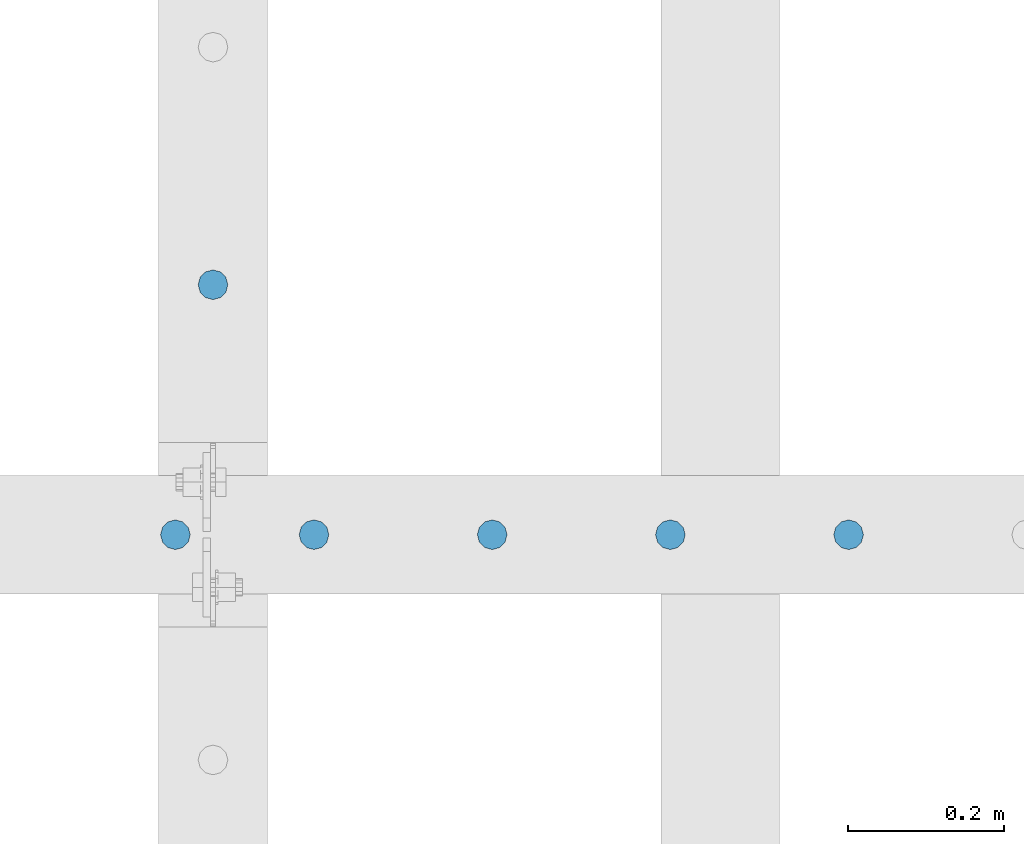
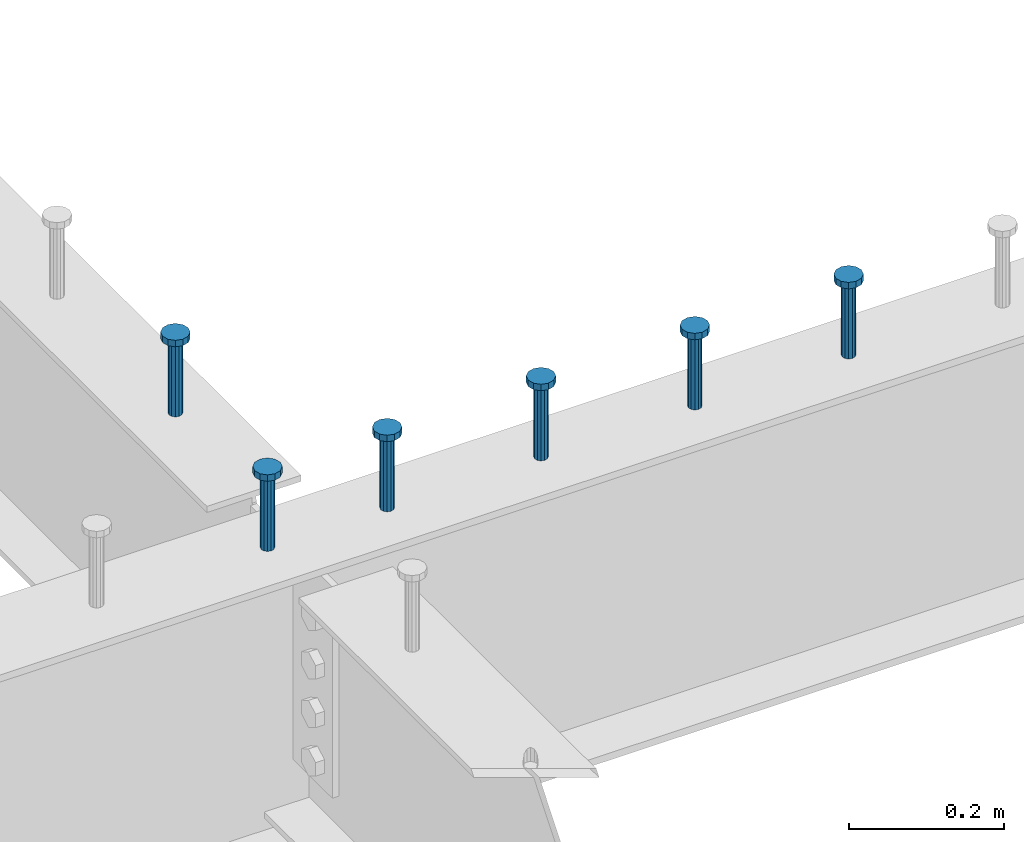
# One storey, part 167 of 975: 6 columns.
"""IFC2X3 building model written with IfcOpenShell, lengths in millimetres."""

from ifc_helpers import new_model, si_unit, frame, origin_with_axes, place, context, subcontext, project, spatial, faceted_brep, material, type_object, element, save


model = new_model("IFC2X3")

# Units and contexts
model_context = context("Model", 3, precision=1e-05, world=origin_with_axes())
body_context = subcontext(model_context, "Body", "Model", "MODEL_VIEW")
ifc_project = project(units=[si_unit("LENGTHUNIT", "METRE", prefix="MILLI"), si_unit("AREAUNIT", "SQUARE_METRE"), si_unit("VOLUMEUNIT", "CUBIC_METRE"), si_unit("MASSUNIT", "GRAM", prefix="KILO"), si_unit("TIMEUNIT", "SECOND"), si_unit("PLANEANGLEUNIT", "RADIAN"), si_unit("SOLIDANGLEUNIT", "STERADIAN"), si_unit("THERMODYNAMICTEMPERATUREUNIT", "DEGREE_CELSIUS"), si_unit("LUMINOUSINTENSITYUNIT", "LUMEN")], contexts=[model_context])

# Site, building, storey
site_placement = place(None, origin_with_axes())
site = spatial("IfcSite", under=ifc_project, at=site_placement, CompositionType="ELEMENT")
building_placement = place(site_placement, origin_with_axes())
building = spatial("IfcBuilding", under=site, at=building_placement, Name="Undefined", CompositionType="ELEMENT")
storey_placement = place(building_placement, origin_with_axes())
storey = spatial("IfcBuildingStorey", under=building, at=storey_placement, Name="Undefined", CompositionType="ELEMENT", Elevation=0.0)

# Columns
ifc_material = material(Name="STEEL/A108")
column_type = type_object("IfcColumnType", Name="STUD_3/4-DIA", PredefinedType="NOTDEFINED")
column_1_placement = place(storey_placement, frame((10858.5662704101, 13712.825, 3937.0), z_axis=(0.0, 1.0, 0.0), x_axis=(0.0, 0.0, 1.0)))
element("IfcColumn", 1, at=column_1_placement, inside=storey, type_object=column_type, material=ifc_material, ObjectType="STUD_3/4-DIA", context=body_context, shape_type="Brep", body=[
    faceted_brep([(0.0, -9.52000045776367, 0.0), (0.0, -8.25, -4.76000022888184), (115.57, -8.25, -4.76000022888184), (115.57, -9.52000045776367, 0.0), (0.0, -4.76000022888184, -8.25), (115.57, -4.76000022888184, -8.25), (0.0, 0.0, -9.52000045776367), (115.57, 0.0, -9.52000045776367), (0.0, 4.76000022888184, -8.25), (115.57, 4.76000022888184, -8.25), (0.0, 8.25, -4.76000022888184), (115.57, 8.25, -4.76000022888184), (0.0, 9.52000045776367, 0.0), (115.57, 9.52000045776367, 0.0), (0.0, 8.25, 4.76000022888184), (115.57, 8.25, 4.76000022888184), (0.0, 4.76000022888184, 8.25), (115.57, 4.76000022888184, 8.25), (0.0, 0.0, 9.52000045776367), (115.57, 0.0, 9.52000045776367), (0.0, -4.76000022888184, 8.25), (115.57, -4.76000022888184, 8.25), (0.0, -8.25, 4.76000022888184), (115.57, -8.25, 4.76000022888184), (116.84, -16.5, -9.52000045776367), (116.84, -19.0499992370605, 0.0), (116.84, -9.52000045776367, -16.5), (116.84, 0.0, -19.0499992370605), (116.84, 9.52000045776367, -16.5), (116.84, 16.5, -9.52000045776367), (116.84, 19.0499992370605, 0.0), (116.84, 16.5, 9.52000045776367), (116.84, 9.52000045776367, 16.5), (116.84, 0.0, 19.0499992370605), (116.84, -9.52000045776367, 16.5), (116.84, -16.5, 9.52000045776367), (127.0, -16.5, -9.52000045776367), (127.0, -19.0499992370605, 0.0), (127.0, -9.52000045776367, -16.5), (127.0, 0.0, -19.0499992370605), (127.0, 9.52000045776367, -16.5), (127.0, 16.5, -9.52000045776367), (127.0, 19.0499992370605, 0.0), (127.0, 16.5, 9.52000045776367), (127.0, 9.52000045776367, 16.5), (127.0, 0.0, 19.0499992370605), (127.0, -9.52000045776367, 16.5), (127.0, -16.5, 9.52000045776367)], [[[0, 1, 2, 3]], [[1, 4, 5, 2]], [[4, 6, 7, 5]], [[6, 8, 9, 7]], [[8, 10, 11, 9]], [[10, 12, 13, 11]], [[12, 14, 15, 13]], [[14, 16, 17, 15]], [[16, 18, 19, 17]], [[18, 20, 21, 19]], [[20, 22, 23, 21]], [[22, 0, 3, 23]], [[22, 20, 18, 16, 14, 12, 10, 8, 6, 4, 1, 0]], [[3, 2, 24, 25]], [[2, 5, 26, 24]], [[5, 7, 27, 26]], [[7, 9, 28, 27]], [[9, 11, 29, 28]], [[11, 13, 30, 29]], [[13, 15, 31, 30]], [[15, 17, 32, 31]], [[17, 19, 33, 32]], [[19, 21, 34, 33]], [[21, 23, 35, 34]], [[23, 3, 25, 35]], [[25, 24, 36, 37]], [[24, 26, 38, 36]], [[26, 27, 39, 38]], [[27, 28, 40, 39]], [[28, 29, 41, 40]], [[29, 30, 42, 41]], [[30, 31, 43, 42]], [[31, 32, 44, 43]], [[32, 33, 45, 44]], [[33, 34, 46, 45]], [[34, 35, 47, 46]], [[35, 25, 37, 47]], [[38, 39, 40, 41, 42, 43, 44, 45, 46, 47, 37, 36]]]),
])
column_2_placement = place(storey_placement, frame((11673.9459584101, 13392.15, 3937.0), z_axis=(0.0, 1.0, 0.0), x_axis=(0.0, 0.0, 1.0)))
element("IfcColumn", 2, at=column_2_placement, inside=storey, type_object=column_type, material=ifc_material, ObjectType="STUD_3/4-DIA", context=body_context, shape_type="Brep", body=[
    faceted_brep([(0.0, -9.52000045776367, 0.0), (0.0, -8.25, -4.76000022888184), (115.57, -8.25, -4.76000022888184), (115.57, -9.52000045776367, 0.0), (0.0, -4.76000022888184, -8.25), (115.57, -4.76000022888184, -8.25), (0.0, 0.0, -9.52000045776367), (115.57, 0.0, -9.52000045776367), (0.0, 4.76000022888184, -8.25), (115.57, 4.76000022888184, -8.25), (0.0, 8.25, -4.76000022888184), (115.57, 8.25, -4.76000022888184), (0.0, 9.52000045776367, 0.0), (115.57, 9.52000045776367, 0.0), (0.0, 8.25, 4.76000022888184), (115.57, 8.25, 4.76000022888184), (0.0, 4.76000022888184, 8.25), (115.57, 4.76000022888184, 8.25), (0.0, 0.0, 9.52000045776367), (115.57, 0.0, 9.52000045776367), (0.0, -4.76000022888184, 8.25), (115.57, -4.76000022888184, 8.25), (0.0, -8.25, 4.76000022888184), (115.57, -8.25, 4.76000022888184), (116.84, -16.5, -9.52000045776367), (116.84, -19.0499992370605, 0.0), (116.84, -9.52000045776367, -16.5), (116.84, 0.0, -19.0499992370605), (116.84, 9.52000045776367, -16.5), (116.84, 16.5, -9.52000045776367), (116.84, 19.0499992370605, 0.0), (116.84, 16.5, 9.52000045776367), (116.84, 9.52000045776367, 16.5), (116.84, 0.0, 19.0499992370605), (116.84, -9.52000045776367, 16.5), (116.84, -16.5, 9.52000045776367), (127.0, -16.5, -9.52000045776367), (127.0, -19.0499992370605, 0.0), (127.0, -9.52000045776367, -16.5), (127.0, 0.0, -19.0499992370605), (127.0, 9.52000045776367, -16.5), (127.0, 16.5, -9.52000045776367), (127.0, 19.0499992370605, 0.0), (127.0, 16.5, 9.52000045776367), (127.0, 9.52000045776367, 16.5), (127.0, 0.0, 19.0499992370605), (127.0, -9.52000045776367, 16.5), (127.0, -16.5, 9.52000045776367)], [[[0, 1, 2, 3]], [[1, 4, 5, 2]], [[4, 6, 7, 5]], [[6, 8, 9, 7]], [[8, 10, 11, 9]], [[10, 12, 13, 11]], [[12, 14, 15, 13]], [[14, 16, 17, 15]], [[16, 18, 19, 17]], [[18, 20, 21, 19]], [[20, 22, 23, 21]], [[22, 0, 3, 23]], [[22, 20, 18, 16, 14, 12, 10, 8, 6, 4, 1, 0]], [[3, 2, 24, 25]], [[2, 5, 26, 24]], [[5, 7, 27, 26]], [[7, 9, 28, 27]], [[9, 11, 29, 28]], [[11, 13, 30, 29]], [[13, 15, 31, 30]], [[15, 17, 32, 31]], [[17, 19, 33, 32]], [[19, 21, 34, 33]], [[21, 23, 35, 34]], [[23, 3, 25, 35]], [[25, 24, 36, 37]], [[24, 26, 38, 36]], [[26, 27, 39, 38]], [[27, 28, 40, 39]], [[28, 29, 41, 40]], [[29, 30, 42, 41]], [[30, 31, 43, 42]], [[31, 32, 44, 43]], [[32, 33, 45, 44]], [[33, 34, 46, 45]], [[34, 35, 47, 46]], [[35, 25, 37, 47]], [[38, 39, 40, 41, 42, 43, 44, 45, 46, 47, 37, 36]]]),
])
column_3_placement = place(storey_placement, frame((11445.3459584101, 13392.15, 3937.0), z_axis=(0.0, 1.0, 0.0), x_axis=(0.0, 0.0, 1.0)))
element("IfcColumn", 3, at=column_3_placement, inside=storey, type_object=column_type, material=ifc_material, ObjectType="STUD_3/4-DIA", context=body_context, shape_type="Brep", body=[
    faceted_brep([(0.0, -9.52000045776367, 0.0), (0.0, -8.25, -4.76000022888184), (115.57, -8.25, -4.76000022888184), (115.57, -9.52000045776367, 0.0), (0.0, -4.76000022888184, -8.25), (115.57, -4.76000022888184, -8.25), (0.0, 0.0, -9.52000045776367), (115.57, 0.0, -9.52000045776367), (0.0, 4.76000022888184, -8.25), (115.57, 4.76000022888184, -8.25), (0.0, 8.25, -4.76000022888184), (115.57, 8.25, -4.76000022888184), (0.0, 9.52000045776367, 0.0), (115.57, 9.52000045776367, 0.0), (0.0, 8.25, 4.76000022888184), (115.57, 8.25, 4.76000022888184), (0.0, 4.76000022888184, 8.25), (115.57, 4.76000022888184, 8.25), (0.0, 0.0, 9.52000045776367), (115.57, 0.0, 9.52000045776367), (0.0, -4.76000022888184, 8.25), (115.57, -4.76000022888184, 8.25), (0.0, -8.25, 4.76000022888184), (115.57, -8.25, 4.76000022888184), (116.84, -16.5, -9.52000045776367), (116.84, -19.0499992370605, 0.0), (116.84, -9.52000045776367, -16.5), (116.84, 0.0, -19.0499992370605), (116.84, 9.52000045776367, -16.5), (116.84, 16.5, -9.52000045776367), (116.84, 19.0499992370605, 0.0), (116.84, 16.5, 9.52000045776367), (116.84, 9.52000045776367, 16.5), (116.84, 0.0, 19.0499992370605), (116.84, -9.52000045776367, 16.5), (116.84, -16.5, 9.52000045776367), (127.0, -16.5, -9.52000045776367), (127.0, -19.0499992370605, 0.0), (127.0, -9.52000045776367, -16.5), (127.0, 0.0, -19.0499992370605), (127.0, 9.52000045776367, -16.5), (127.0, 16.5, -9.52000045776367), (127.0, 19.0499992370605, 0.0), (127.0, 16.5, 9.52000045776367), (127.0, 9.52000045776367, 16.5), (127.0, 0.0, 19.0499992370605), (127.0, -9.52000045776367, 16.5), (127.0, -16.5, 9.52000045776367)], [[[0, 1, 2, 3]], [[1, 4, 5, 2]], [[4, 6, 7, 5]], [[6, 8, 9, 7]], [[8, 10, 11, 9]], [[10, 12, 13, 11]], [[12, 14, 15, 13]], [[14, 16, 17, 15]], [[16, 18, 19, 17]], [[18, 20, 21, 19]], [[20, 22, 23, 21]], [[22, 0, 3, 23]], [[22, 20, 18, 16, 14, 12, 10, 8, 6, 4, 1, 0]], [[3, 2, 24, 25]], [[2, 5, 26, 24]], [[5, 7, 27, 26]], [[7, 9, 28, 27]], [[9, 11, 29, 28]], [[11, 13, 30, 29]], [[13, 15, 31, 30]], [[15, 17, 32, 31]], [[17, 19, 33, 32]], [[19, 21, 34, 33]], [[21, 23, 35, 34]], [[23, 3, 25, 35]], [[25, 24, 36, 37]], [[24, 26, 38, 36]], [[26, 27, 39, 38]], [[27, 28, 40, 39]], [[28, 29, 41, 40]], [[29, 30, 42, 41]], [[30, 31, 43, 42]], [[31, 32, 44, 43]], [[32, 33, 45, 44]], [[33, 34, 46, 45]], [[34, 35, 47, 46]], [[35, 25, 37, 47]], [[38, 39, 40, 41, 42, 43, 44, 45, 46, 47, 37, 36]]]),
])
column_4_placement = place(storey_placement, frame((11216.7459584101, 13392.15, 3937.0), z_axis=(0.0, 1.0, 0.0), x_axis=(0.0, 0.0, 1.0)))
element("IfcColumn", 4, at=column_4_placement, inside=storey, type_object=column_type, material=ifc_material, ObjectType="STUD_3/4-DIA", context=body_context, shape_type="Brep", body=[
    faceted_brep([(0.0, -9.52000045776367, 0.0), (0.0, -8.25, -4.76000022888184), (115.57, -8.25, -4.76000022888184), (115.57, -9.52000045776367, 0.0), (0.0, -4.76000022888184, -8.25), (115.57, -4.76000022888184, -8.25), (0.0, 0.0, -9.52000045776367), (115.57, 0.0, -9.52000045776367), (0.0, 4.76000022888184, -8.25), (115.57, 4.76000022888184, -8.25), (0.0, 8.25, -4.76000022888184), (115.57, 8.25, -4.76000022888184), (0.0, 9.52000045776367, 0.0), (115.57, 9.52000045776367, 0.0), (0.0, 8.25, 4.76000022888184), (115.57, 8.25, 4.76000022888184), (0.0, 4.76000022888184, 8.25), (115.57, 4.76000022888184, 8.25), (0.0, 0.0, 9.52000045776367), (115.57, 0.0, 9.52000045776367), (0.0, -4.76000022888184, 8.25), (115.57, -4.76000022888184, 8.25), (0.0, -8.25, 4.76000022888184), (115.57, -8.25, 4.76000022888184), (116.84, -16.5, -9.52000045776367), (116.84, -19.0499992370605, 0.0), (116.84, -9.52000045776367, -16.5), (116.84, 0.0, -19.0499992370605), (116.84, 9.52000045776367, -16.5), (116.84, 16.5, -9.52000045776367), (116.84, 19.0499992370605, 0.0), (116.84, 16.5, 9.52000045776367), (116.84, 9.52000045776367, 16.5), (116.84, 0.0, 19.0499992370605), (116.84, -9.52000045776367, 16.5), (116.84, -16.5, 9.52000045776367), (127.0, -16.5, -9.52000045776367), (127.0, -19.0499992370605, 0.0), (127.0, -9.52000045776367, -16.5), (127.0, 0.0, -19.0499992370605), (127.0, 9.52000045776367, -16.5), (127.0, 16.5, -9.52000045776367), (127.0, 19.0499992370605, 0.0), (127.0, 16.5, 9.52000045776367), (127.0, 9.52000045776367, 16.5), (127.0, 0.0, 19.0499992370605), (127.0, -9.52000045776367, 16.5), (127.0, -16.5, 9.52000045776367)], [[[0, 1, 2, 3]], [[1, 4, 5, 2]], [[4, 6, 7, 5]], [[6, 8, 9, 7]], [[8, 10, 11, 9]], [[10, 12, 13, 11]], [[12, 14, 15, 13]], [[14, 16, 17, 15]], [[16, 18, 19, 17]], [[18, 20, 21, 19]], [[20, 22, 23, 21]], [[22, 0, 3, 23]], [[22, 20, 18, 16, 14, 12, 10, 8, 6, 4, 1, 0]], [[3, 2, 24, 25]], [[2, 5, 26, 24]], [[5, 7, 27, 26]], [[7, 9, 28, 27]], [[9, 11, 29, 28]], [[11, 13, 30, 29]], [[13, 15, 31, 30]], [[15, 17, 32, 31]], [[17, 19, 33, 32]], [[19, 21, 34, 33]], [[21, 23, 35, 34]], [[23, 3, 25, 35]], [[25, 24, 36, 37]], [[24, 26, 38, 36]], [[26, 27, 39, 38]], [[27, 28, 40, 39]], [[28, 29, 41, 40]], [[29, 30, 42, 41]], [[30, 31, 43, 42]], [[31, 32, 44, 43]], [[32, 33, 45, 44]], [[33, 34, 46, 45]], [[34, 35, 47, 46]], [[35, 25, 37, 47]], [[38, 39, 40, 41, 42, 43, 44, 45, 46, 47, 37, 36]]]),
])
column_5_placement = place(storey_placement, frame((10988.1459584101, 13392.15, 3937.0), z_axis=(0.0, 1.0, 0.0), x_axis=(0.0, 0.0, 1.0)))
element("IfcColumn", 5, at=column_5_placement, inside=storey, type_object=column_type, material=ifc_material, ObjectType="STUD_3/4-DIA", context=body_context, shape_type="Brep", body=[
    faceted_brep([(0.0, -9.52000045776367, 0.0), (0.0, -8.25, -4.76000022888184), (115.57, -8.25, -4.76000022888184), (115.57, -9.52000045776367, 0.0), (0.0, -4.76000022888184, -8.25), (115.57, -4.76000022888184, -8.25), (0.0, 0.0, -9.52000045776367), (115.57, 0.0, -9.52000045776367), (0.0, 4.76000022888184, -8.25), (115.57, 4.76000022888184, -8.25), (0.0, 8.25, -4.76000022888184), (115.57, 8.25, -4.76000022888184), (0.0, 9.52000045776367, 0.0), (115.57, 9.52000045776367, 0.0), (0.0, 8.25, 4.76000022888184), (115.57, 8.25, 4.76000022888184), (0.0, 4.76000022888184, 8.25), (115.57, 4.76000022888184, 8.25), (0.0, 0.0, 9.52000045776367), (115.57, 0.0, 9.52000045776367), (0.0, -4.76000022888184, 8.25), (115.57, -4.76000022888184, 8.25), (0.0, -8.25, 4.76000022888184), (115.57, -8.25, 4.76000022888184), (116.84, -16.5, -9.52000045776367), (116.84, -19.0499992370605, 0.0), (116.84, -9.52000045776367, -16.5), (116.84, 0.0, -19.0499992370605), (116.84, 9.52000045776367, -16.5), (116.84, 16.5, -9.52000045776367), (116.84, 19.0499992370605, 0.0), (116.84, 16.5, 9.52000045776367), (116.84, 9.52000045776367, 16.5), (116.84, 0.0, 19.0499992370605), (116.84, -9.52000045776367, 16.5), (116.84, -16.5, 9.52000045776367), (127.0, -16.5, -9.52000045776367), (127.0, -19.0499992370605, 0.0), (127.0, -9.52000045776367, -16.5), (127.0, 0.0, -19.0499992370605), (127.0, 9.52000045776367, -16.5), (127.0, 16.5, -9.52000045776367), (127.0, 19.0499992370605, 0.0), (127.0, 16.5, 9.52000045776367), (127.0, 9.52000045776367, 16.5), (127.0, 0.0, 19.0499992370605), (127.0, -9.52000045776367, 16.5), (127.0, -16.5, 9.52000045776367)], [[[0, 1, 2, 3]], [[1, 4, 5, 2]], [[4, 6, 7, 5]], [[6, 8, 9, 7]], [[8, 10, 11, 9]], [[10, 12, 13, 11]], [[12, 14, 15, 13]], [[14, 16, 17, 15]], [[16, 18, 19, 17]], [[18, 20, 21, 19]], [[20, 22, 23, 21]], [[22, 0, 3, 23]], [[22, 20, 18, 16, 14, 12, 10, 8, 6, 4, 1, 0]], [[3, 2, 24, 25]], [[2, 5, 26, 24]], [[5, 7, 27, 26]], [[7, 9, 28, 27]], [[9, 11, 29, 28]], [[11, 13, 30, 29]], [[13, 15, 31, 30]], [[15, 17, 32, 31]], [[17, 19, 33, 32]], [[19, 21, 34, 33]], [[21, 23, 35, 34]], [[23, 3, 25, 35]], [[25, 24, 36, 37]], [[24, 26, 38, 36]], [[26, 27, 39, 38]], [[27, 28, 40, 39]], [[28, 29, 41, 40]], [[29, 30, 42, 41]], [[30, 31, 43, 42]], [[31, 32, 44, 43]], [[32, 33, 45, 44]], [[33, 34, 46, 45]], [[34, 35, 47, 46]], [[35, 25, 37, 47]], [[38, 39, 40, 41, 42, 43, 44, 45, 46, 47, 37, 36]]]),
])
column_6_placement = place(storey_placement, frame((10810.3459584101, 13392.15, 3937.0), z_axis=(0.0, 1.0, 0.0), x_axis=(0.0, 0.0, 1.0)))
element("IfcColumn", 6, at=column_6_placement, inside=storey, type_object=column_type, material=ifc_material, ObjectType="STUD_3/4-DIA", context=body_context, shape_type="Brep", body=[
    faceted_brep([(0.0, -9.52000045776367, 0.0), (0.0, -8.25, -4.76000022888184), (115.57, -8.25, -4.76000022888184), (115.57, -9.52000045776367, 0.0), (0.0, -4.76000022888184, -8.25), (115.57, -4.76000022888184, -8.25), (0.0, 0.0, -9.52000045776367), (115.57, 0.0, -9.52000045776367), (0.0, 4.76000022888184, -8.25), (115.57, 4.76000022888184, -8.25), (0.0, 8.25, -4.76000022888184), (115.57, 8.25, -4.76000022888184), (0.0, 9.52000045776367, 0.0), (115.57, 9.52000045776367, 0.0), (0.0, 8.25, 4.76000022888184), (115.57, 8.25, 4.76000022888184), (0.0, 4.76000022888184, 8.25), (115.57, 4.76000022888184, 8.25), (0.0, 0.0, 9.52000045776367), (115.57, 0.0, 9.52000045776367), (0.0, -4.76000022888184, 8.25), (115.57, -4.76000022888184, 8.25), (0.0, -8.25, 4.76000022888184), (115.57, -8.25, 4.76000022888184), (116.84, -16.5, -9.52000045776367), (116.84, -19.0499992370605, 0.0), (116.84, -9.52000045776367, -16.5), (116.84, 0.0, -19.0499992370605), (116.84, 9.52000045776367, -16.5), (116.84, 16.5, -9.52000045776367), (116.84, 19.0499992370605, 0.0), (116.84, 16.5, 9.52000045776367), (116.84, 9.52000045776367, 16.5), (116.84, 0.0, 19.0499992370605), (116.84, -9.52000045776367, 16.5), (116.84, -16.5, 9.52000045776367), (127.0, -16.5, -9.52000045776367), (127.0, -19.0499992370605, 0.0), (127.0, -9.52000045776367, -16.5), (127.0, 0.0, -19.0499992370605), (127.0, 9.52000045776367, -16.5), (127.0, 16.5, -9.52000045776367), (127.0, 19.0499992370605, 0.0), (127.0, 16.5, 9.52000045776367), (127.0, 9.52000045776367, 16.5), (127.0, 0.0, 19.0499992370605), (127.0, -9.52000045776367, 16.5), (127.0, -16.5, 9.52000045776367)], [[[0, 1, 2, 3]], [[1, 4, 5, 2]], [[4, 6, 7, 5]], [[6, 8, 9, 7]], [[8, 10, 11, 9]], [[10, 12, 13, 11]], [[12, 14, 15, 13]], [[14, 16, 17, 15]], [[16, 18, 19, 17]], [[18, 20, 21, 19]], [[20, 22, 23, 21]], [[22, 0, 3, 23]], [[22, 20, 18, 16, 14, 12, 10, 8, 6, 4, 1, 0]], [[3, 2, 24, 25]], [[2, 5, 26, 24]], [[5, 7, 27, 26]], [[7, 9, 28, 27]], [[9, 11, 29, 28]], [[11, 13, 30, 29]], [[13, 15, 31, 30]], [[15, 17, 32, 31]], [[17, 19, 33, 32]], [[19, 21, 34, 33]], [[21, 23, 35, 34]], [[23, 3, 25, 35]], [[25, 24, 36, 37]], [[24, 26, 38, 36]], [[26, 27, 39, 38]], [[27, 28, 40, 39]], [[28, 29, 41, 40]], [[29, 30, 42, 41]], [[30, 31, 43, 42]], [[31, 32, 44, 43]], [[32, 33, 45, 44]], [[33, 34, 46, 45]], [[34, 35, 47, 46]], [[35, 25, 37, 47]], [[38, 39, 40, 41, 42, 43, 44, 45, 46, 47, 37, 36]]]),
])

save(model, "model.ifc")
